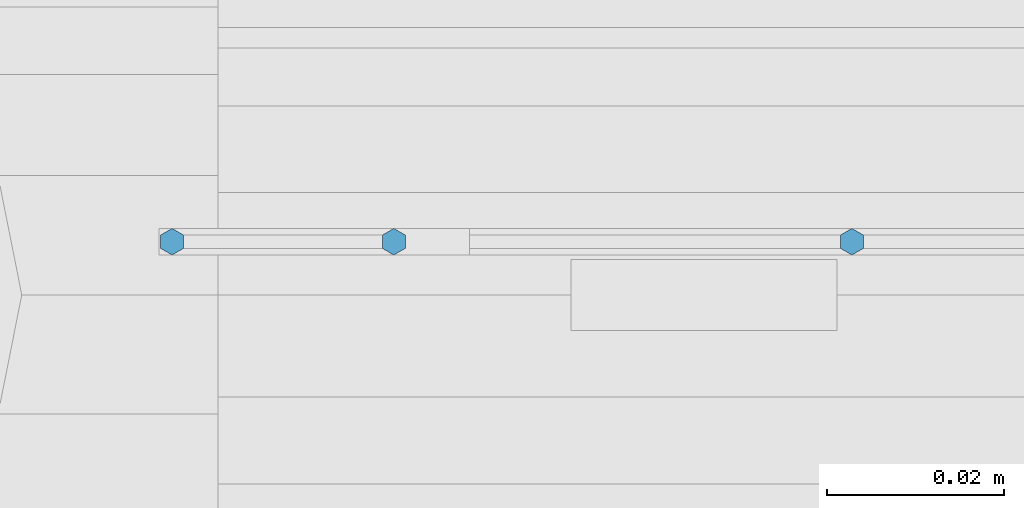
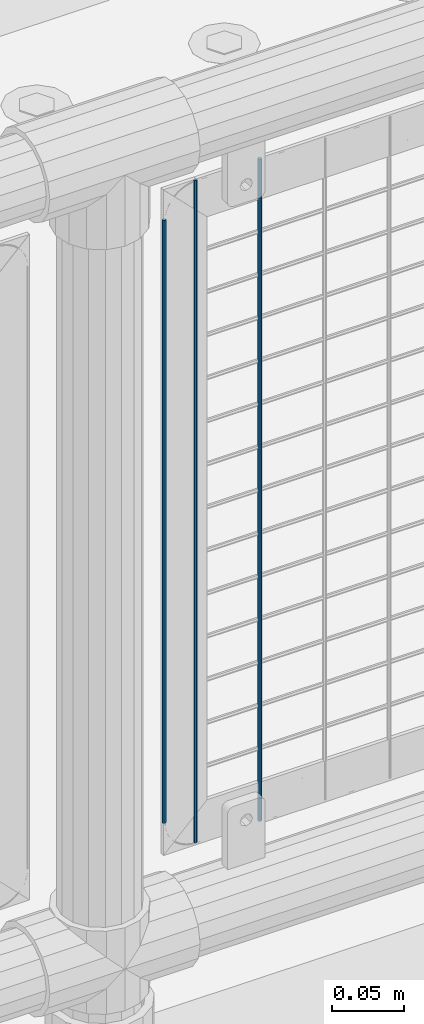
# One storey, part 76 of 240: 3 columns.
"""IFC2X3 building model written with IfcOpenShell, lengths in millimetres."""

from ifc_helpers import new_model, si_unit, frame, origin_with_axes, place, context, subcontext, project, spatial, faceted_brep, material, type_object, element, save


model = new_model("IFC2X3")

# Units and contexts
model_context = context("Model", 3, precision=1e-05, world=origin_with_axes())
body_context = subcontext(model_context, "Body", "Model", "MODEL_VIEW")
ifc_project = project(units=[si_unit("LENGTHUNIT", "METRE", prefix="MILLI"), si_unit("AREAUNIT", "SQUARE_METRE"), si_unit("VOLUMEUNIT", "CUBIC_METRE"), si_unit("MASSUNIT", "GRAM", prefix="KILO"), si_unit("TIMEUNIT", "SECOND"), si_unit("PLANEANGLEUNIT", "RADIAN"), si_unit("SOLIDANGLEUNIT", "STERADIAN"), si_unit("THERMODYNAMICTEMPERATUREUNIT", "DEGREE_CELSIUS"), si_unit("LUMINOUSINTENSITYUNIT", "LUMEN")], contexts=[model_context])

# Site, building, storey
site_placement = place(None, origin_with_axes())
site = spatial("IfcSite", under=ifc_project, at=site_placement, CompositionType="ELEMENT")
building_placement = place(site_placement, origin_with_axes())
building = spatial("IfcBuilding", under=site, at=building_placement, Name="Standard", CompositionType="ELEMENT")
storey_placement = place(building_placement, origin_with_axes())
storey = spatial("IfcBuildingStorey", under=building, at=storey_placement, Name="Undefined", CompositionType="ELEMENT", Elevation=0.0)

# Columns
ifc_material = material(Name="Misc_Undefined")
column_type = type_object("IfcColumnType", Name="D3", PredefinedType="NOTDEFINED")
column_1_placement = place(storey_placement, frame((46518.655, 34670.5, 353.02), z_axis=(-1.0, 0.0, 0.0), x_axis=(0.0, 0.0, 1.0)))
element("IfcColumn", 1, at=column_1_placement, inside=storey, type_object=column_type, material=ifc_material, ObjectType="D3", context=body_context, shape_type="Brep", body=[
    faceted_brep([(-7.27595761418343e-12, -1.49999999999272, 0.0), (-7.27595761418343e-12, -0.749999999992724, -1.29903810567669), (560.0, -0.75, -1.29903810567339), (560.0, -1.5, 0.0), (0.0, 0.750000000007276, -1.29903810567669), (560.0, 0.75, -1.29903810567339), (0.0, 1.50000000000728, 0.0), (560.0, 1.5, 0.0), (0.0, 0.750000000007276, 1.29903810567669), (560.0, 0.75, 1.29903810567339), (-7.27595761418343e-12, -0.749999999992724, 1.29903810567669), (560.0, -0.75, 1.29903810567339)], [[[0, 1, 2, 3]], [[1, 4, 5, 2]], [[4, 6, 7, 5]], [[6, 8, 9, 7]], [[8, 10, 11, 9]], [[10, 0, 3, 11]], [[5, 7, 9, 11, 3, 2]], [[10, 8, 6, 4, 1, 0]]]),
])
column_2_placement = place(storey_placement, frame((46442.0, 34670.5, 378.02), z_axis=(-1.0, 0.0, 0.0), x_axis=(0.0, 0.0, 1.0)))
element("IfcColumn", 2, at=column_2_placement, inside=storey, type_object=column_type, material=ifc_material, ObjectType="D3", context=body_context, shape_type="Brep", body=[
    faceted_brep([(-7.27595761418343e-12, -1.49999999999272, 0.0), (-7.27595761418343e-12, -0.749999999992724, -1.29903810567669), (510.0, -0.75, -1.29903810567339), (510.0, -1.5, 0.0), (0.0, 0.750000000007276, -1.29903810567669), (510.0, 0.75, -1.29903810567339), (0.0, 1.50000000000728, 0.0), (510.0, 1.5, 0.0), (0.0, 0.750000000007276, 1.29903810567669), (510.0, 0.75, 1.29903810567339), (-7.27595761418343e-12, -0.749999999992724, 1.29903810567669), (510.0, -0.75, 1.29903810567339)], [[[0, 1, 2, 3]], [[1, 4, 5, 2]], [[4, 6, 7, 5]], [[6, 8, 9, 7]], [[8, 10, 11, 9]], [[10, 0, 3, 11]], [[5, 7, 9, 11, 3, 2]], [[10, 8, 6, 4, 1, 0]]]),
])
column_3_placement = place(storey_placement, frame((46467.0, 34670.5, 353.02), z_axis=(-1.0, 0.0, 0.0), x_axis=(0.0, 0.0, 1.0)))
element("IfcColumn", 3, at=column_3_placement, inside=storey, type_object=column_type, material=ifc_material, ObjectType="D3", context=body_context, shape_type="Brep", body=[
    faceted_brep([(-7.27595761418343e-12, -1.49999999999272, 0.0), (-7.27595761418343e-12, -0.749999999992724, -1.29903810567669), (560.0, -0.75, -1.29903810567339), (560.0, -1.5, 0.0), (0.0, 0.750000000007276, -1.29903810567669), (560.0, 0.75, -1.29903810567339), (0.0, 1.50000000000728, 0.0), (560.0, 1.5, 0.0), (0.0, 0.750000000007276, 1.29903810567669), (560.0, 0.75, 1.29903810567339), (-7.27595761418343e-12, -0.749999999992724, 1.29903810567669), (560.0, -0.75, 1.29903810567339)], [[[0, 1, 2, 3]], [[1, 4, 5, 2]], [[4, 6, 7, 5]], [[6, 8, 9, 7]], [[8, 10, 11, 9]], [[10, 0, 3, 11]], [[5, 7, 9, 11, 3, 2]], [[10, 8, 6, 4, 1, 0]]]),
])

save(model, "model.ifc")
